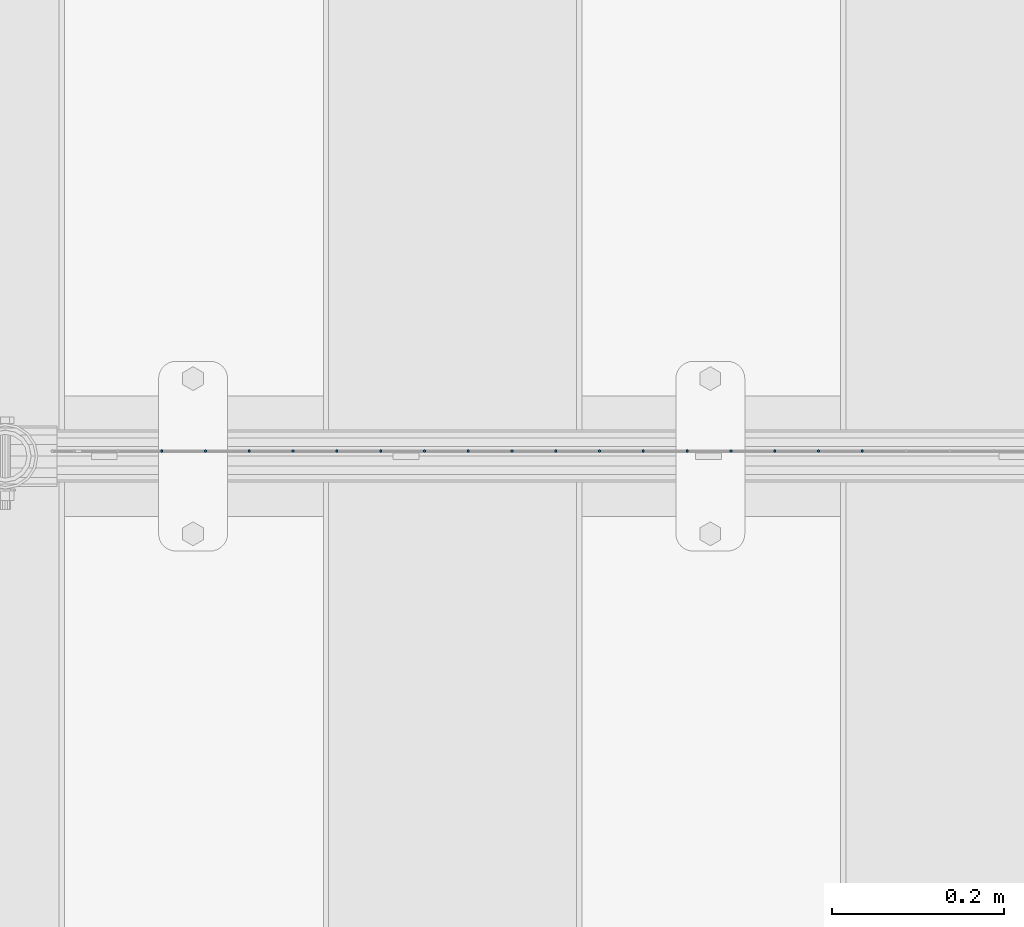
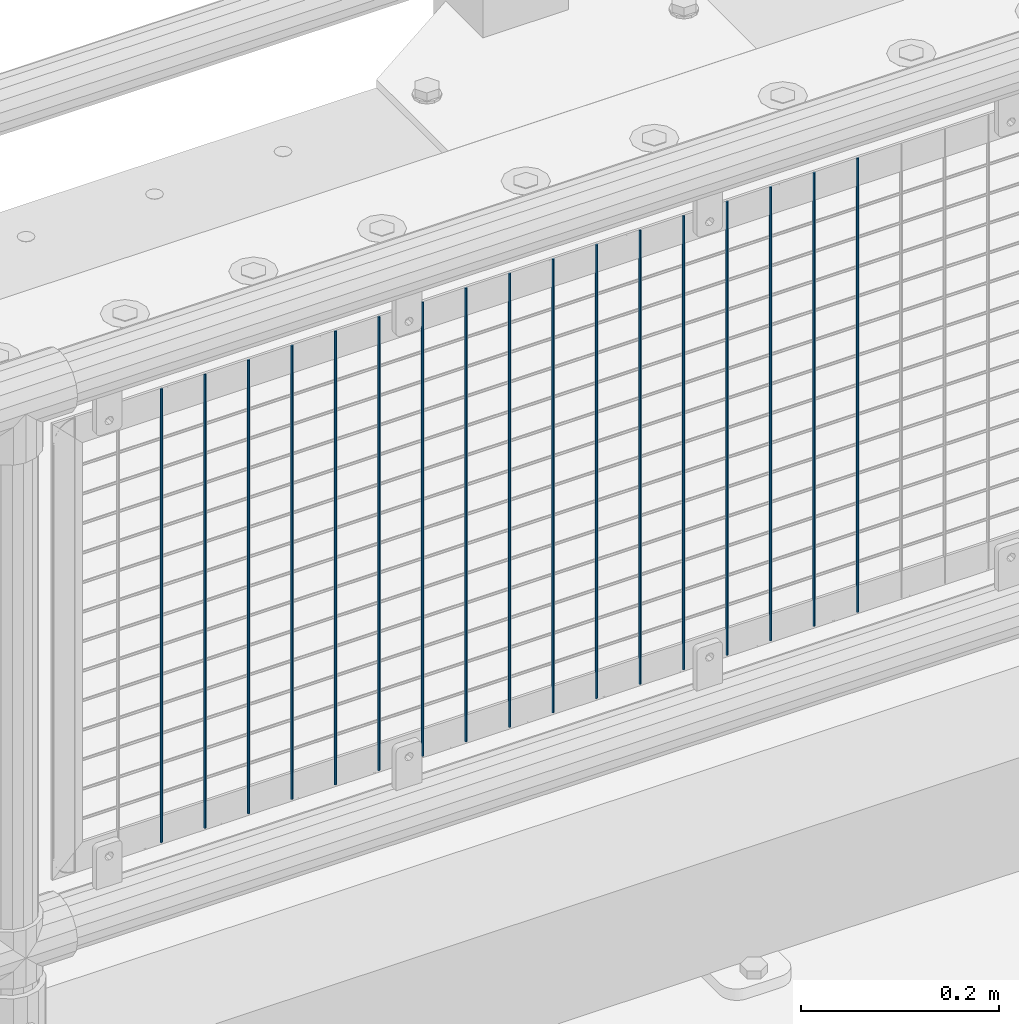
# One storey, part 102 of 242: 17 columns.
"""IFC2X3 building model written with IfcOpenShell, lengths in millimetres."""

from ifc_helpers import new_model, si_unit, frame, origin_with_axes, place, context, subcontext, project, spatial, faceted_brep, material, type_object, element, save


model = new_model("IFC2X3")

# Units and contexts
model_context = context("Model", 3, precision=1e-05, world=origin_with_axes())
body_context = subcontext(model_context, "Body", "Model", "MODEL_VIEW")
ifc_project = project(units=[si_unit("LENGTHUNIT", "METRE", prefix="MILLI"), si_unit("AREAUNIT", "SQUARE_METRE"), si_unit("VOLUMEUNIT", "CUBIC_METRE"), si_unit("MASSUNIT", "GRAM", prefix="KILO"), si_unit("TIMEUNIT", "SECOND"), si_unit("PLANEANGLEUNIT", "RADIAN"), si_unit("SOLIDANGLEUNIT", "STERADIAN"), si_unit("THERMODYNAMICTEMPERATUREUNIT", "DEGREE_CELSIUS"), si_unit("LUMINOUSINTENSITYUNIT", "LUMEN")], contexts=[model_context])

# Site, building, storey
site_placement = place(None, origin_with_axes())
site = spatial("IfcSite", under=ifc_project, at=site_placement, CompositionType="ELEMENT")
building_placement = place(site_placement, origin_with_axes())
building = spatial("IfcBuilding", under=site, at=building_placement, Name="Standard", CompositionType="ELEMENT")
storey_placement = place(building_placement, origin_with_axes())
storey = spatial("IfcBuildingStorey", under=building, at=storey_placement, Name="Undefined", CompositionType="ELEMENT", Elevation=0.0)

# Columns
ifc_material = material(Name="Misc_Undefined")
column_type = type_object("IfcColumnType", Name="D3", PredefinedType="NOTDEFINED")
for number, where, z_axis, x_axis in (
    (1, (-24504.726, -19329.5, 353.02), (-1.0, 0.0, 0.0), (0.0, 0.0, 1.0)),
    (2, (-24555.519, -19329.5, 353.02), (-1.0, 0.0, 0.0), (0.0, 0.0, 1.0)),
    (3, (-24606.312, -19329.5, 353.02), (-1.0, 0.0, 0.0), (0.0, 0.0, 1.0)),
    (4, (-24657.105, -19329.5, 353.02), (-1.0, 0.0, 0.0), (0.0, 0.0, 1.0)),
    (5, (-24707.898, -19329.5, 353.02), (-1.0, 0.0, 0.0), (0.0, 0.0, 1.0)),
    (6, (-24758.691, -19329.5, 353.02), (-1.0, 0.0, 0.0), (0.0, 0.0, 1.0)),
    (7, (-24809.484, -19329.5, 353.02), (-1.0, 0.0, 0.0), (0.0, 0.0, 1.0)),
    (8, (-24860.277, -19329.5, 353.02), (-1.0, 0.0, 0.0), (0.0, 0.0, 1.0)),
    (9, (-24911.07, -19329.5, 353.02), (-1.0, 0.0, 0.0), (0.0, 0.0, 1.0)),
    (10, (-24961.863, -19329.5, 353.02), (-1.0, 0.0, 0.0), (0.0, 0.0, 1.0)),
    (11, (-25012.656, -19329.5, 353.02), (-1.0, 0.0, 0.0), (0.0, 0.0, 1.0)),
    (12, (-25063.449, -19329.5, 353.02), (-1.0, 0.0, 0.0), (0.0, 0.0, 1.0)),
    (13, (-25114.242, -19329.5, 353.02), (-1.0, 0.0, 0.0), (0.0, 0.0, 1.0)),
    (14, (-25165.035, -19329.5, 353.02), (-1.0, 0.0, 0.0), (0.0, 0.0, 1.0)),
    (15, (-25215.828, -19329.5, 353.02), (-1.0, 0.0, 0.0), (0.0, 0.0, 1.0)),
    (16, (-25266.621, -19329.5, 353.02), (-1.0, 0.0, 0.0), (0.0, 0.0, 1.0)),
    (17, (-25317.414, -19329.5, 353.02), (-1.0, 0.0, 0.0), (0.0, 0.0, 1.0)),
):
    element("IfcColumn", number, at=place(storey_placement, frame(where, z_axis=z_axis, x_axis=x_axis)), inside=storey, type_object=column_type, material=ifc_material, ObjectType="D3", context=body_context, shape_type="Brep", body=[
        faceted_brep([(0.0, -1.50000000000364, 0.0), (-3.63797880709171e-12, -0.750000000003638, -1.29903810567669), (560.0, -0.75, -1.29903810567703), (560.0, -1.5, 0.0), (0.0, 0.749999999996362, -1.29903810567669), (560.0, 0.75, -1.29903810567703), (-3.63797880709171e-12, 1.49999999999636, 0.0), (560.0, 1.5, 0.0), (0.0, 0.749999999996362, 1.29903810567669), (560.0, 0.75, 1.29903810567703), (-3.63797880709171e-12, -0.750000000003638, 1.29903810567669), (560.0, -0.75, 1.29903810567703)], [[[0, 1, 2, 3]], [[1, 4, 5, 2]], [[4, 6, 7, 5]], [[6, 8, 9, 7]], [[8, 10, 11, 9]], [[10, 0, 3, 11]], [[5, 7, 9, 11, 3, 2]], [[10, 8, 6, 4, 1, 0]]]),
    ])

save(model, "model.ifc")
